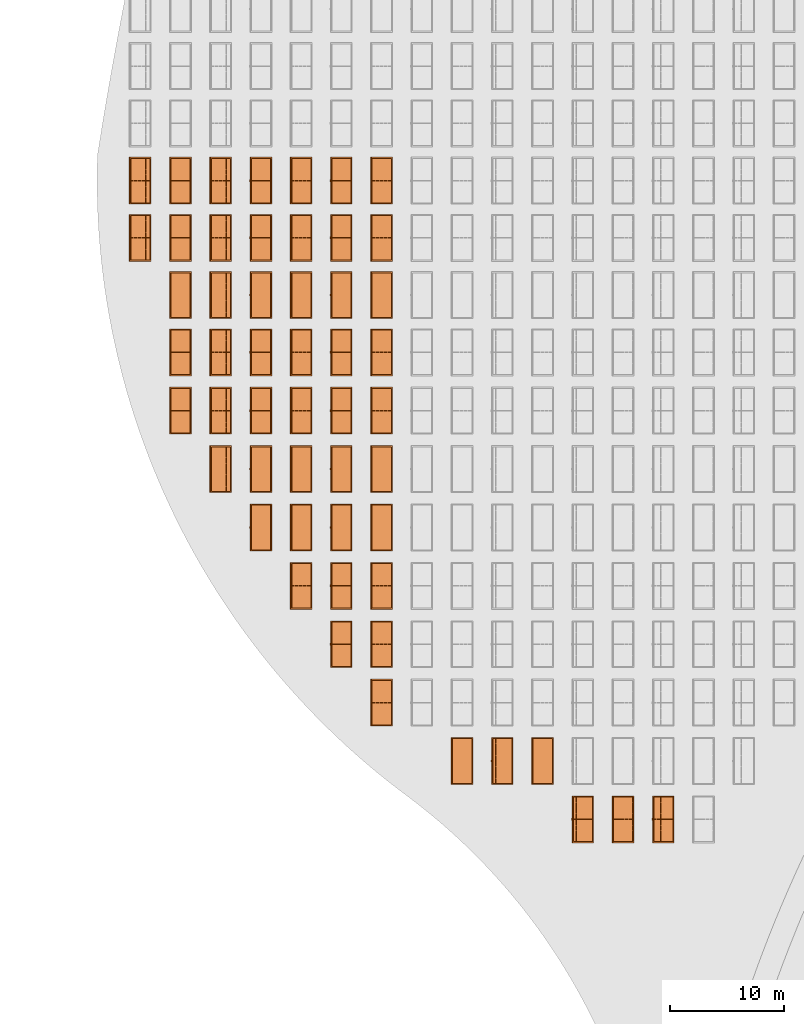
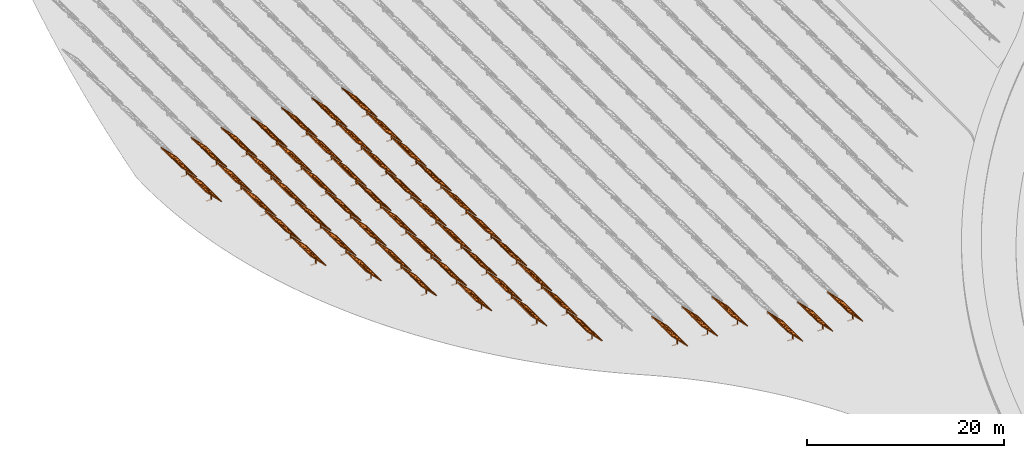
# One storey, part 15 of 39: 53 proxies.
"""IFC2X3 building model written with IfcOpenShell, lengths in millimetres."""

from ifc_helpers import new_model, entity, si_unit, converted_unit, derived_unit, direction, frame, frame_2d, origin, origin_2d_with_axis, place, context, subcontext, project, spatial, polyline, rectangle, outline, extrude, source, transform, mapped, material, material_list, element, save


model = new_model("IFC2X3")

# Units and contexts
model_context = context("Model", 3, precision=1e-06, world=origin(), true_north=direction((2.0, 6.12303176911189e-17, 1.0)))
context_of_model = context(None, 3, precision=1e-06, world=origin(), true_north=direction((2.0, 6.12303176911189e-17, 1.0)))
body_context = subcontext(model_context, "Body", "Model", "MODEL_VIEW")
ifc_project = project(units=[si_unit("LENGTHUNIT", "METRE", prefix="MILLI"), si_unit("AREAUNIT", "SQUARE_METRE", prefix="MILLI"), si_unit("VOLUMEUNIT", "CUBIC_METRE", prefix="MILLI"), converted_unit("PLANEANGLEUNIT", "DEGREE", entity("IfcRatioMeasure", 0.0174532925199433), si_unit("PLANEANGLEUNIT", "RADIAN"), dimensions=[0, 0, 0, 0, 0, 0, 0]), si_unit("MASSUNIT", "GRAM", prefix="KILO"), si_unit("TIMEUNIT", "SECOND"), si_unit("THERMODYNAMICTEMPERATUREUNIT", "KELVIN"), derived_unit("THERMALTRANSMITTANCEUNIT", [(si_unit("MASSUNIT", "GRAM", prefix="KILO"), 1), (si_unit("THERMODYNAMICTEMPERATUREUNIT", "KELVIN"), -1), (si_unit("TIMEUNIT", "SECOND"), -3)]), derived_unit("VOLUMETRICFLOWRATEUNIT", [(si_unit("LENGTHUNIT", "METRE"), 3), (si_unit("TIMEUNIT", "SECOND"), -1)])], contexts=[model_context, context_of_model])

# Site, building, storey
site_placement = place(None, origin())
site = spatial("IfcSite", under=ifc_project, at=site_placement, CompositionType="ELEMENT")
building_placement = place(site_placement, origin())
building = spatial("IfcBuilding", under=site, at=building_placement, CompositionType="ELEMENT")
storey_placement = place(building_placement, frame((0.0, 0.0, 4000.0)))
storey = spatial("IfcBuildingStorey", under=building, at=storey_placement, Name="Level 2", CompositionType="ELEMENT", Elevation=4000.0)

# Proxies
ifc_material_1 = material(Name="Stand-Steel")
ifc_material_2 = material(Name="Aluminium")
ifc_material_3 = material(Name="Glass")
ifc_material_list_1 = material_list([ifc_material_1, ifc_material_2, ifc_material_3])
shared_shape = source(origin(), body_context, "Body", "SweptSolid", [
    extrude(outline(polyline([(-629.526235435404, -220.0), (329.763117717702, -220.0), (329.763117717703, 410.0), (299.763117717703, 410.0), (299.763117717702, -190.0), (-629.526235435404, -190.0), (-629.526235435404, -220.0)])), frame((-190.00003127179, -100.0, 299.763117717707), z_axis=(0.0, 1.0, 0.0), x_axis=(0.0, 0.0, -1.0)), (0.0, 0.0, 1.0), 200.0),
    extrude(rectangle(XDim=20.0000000000001, YDim=200.0, at=frame_2d((0.0, -7.105427357601e-14), x_axis=(0.0, 1.0))), frame((-7.07109908365613, 0.0, 922.21828534124), z_axis=(-0.70710678118654, 0.0, 0.707106781186555), x_axis=(0.0, 1.0, 0.0)), (0.0, 0.0, 1.0), 2600.0),
    extrude(rectangle(XDim=24.9999999999997, YDim=24.9999999999999, at=frame_2d((2.87769807982841e-13, -9.50350909079134e-14), x_axis=(1.0, 0.0))), frame((-1449.56292018118, -1950.0, 2449.57494522722), z_axis=(0.0, 1.0, 0.0), x_axis=(-0.707106781186548, 0.0, -0.707106781186548)), (0.0, 0.0, 1.0), 3900.0),
    extrude(rectangle(XDim=24.9999999999999, YDim=25.0000000000001, at=origin_2d_with_axis()), frame((-1096.0095295879, -1950.0, 2096.02155463395), z_axis=(0.0, 1.0, 0.0), x_axis=(-0.707106781186542, 0.0, -0.707106781186553)), (0.0, 0.0, 1.0), 3900.0),
    extrude(rectangle(XDim=24.9999999999999, YDim=25.0000000000001, at=origin_2d_with_axis()), frame((-742.456138994631, -1950.0, 1742.46816404067), z_axis=(0.0, 1.0, 0.0), x_axis=(-0.707106781186542, 0.0, -0.707106781186553)), (0.0, 0.0, 1.0), 3900.0),
    extrude(rectangle(XDim=25.0, YDim=24.9999999999997, at=frame_2d((-7.19424519957101e-14, 1.19904086659517e-13), x_axis=(1.0, 0.0))), frame((-388.902748401358, -1950.0, 1388.9147734474), z_axis=(0.0, 1.0, 0.0), x_axis=(-0.707106781186545, 0.0, -0.70710678118655)), (0.0, 0.0, 1.0), 3900.0),
    extrude(rectangle(XDim=25.0000000000002, YDim=25.0, at=frame_2d((1.35891298214119e-13, 6.21724893790088e-15), x_axis=(0.0, 1.0))), frame((-35.3553703311048, 1500.0, 1035.35537033109), z_axis=(-0.707106781186544, 0.0, 0.707106781186551), x_axis=(0.0, 1.0, 0.0)), (0.0, 0.0, 1.0), 2440.0),
    extrude(rectangle(XDim=25.0000000000002, YDim=25.0, at=frame_2d((0.0, 1.77635683940025e-15), x_axis=(0.0, 1.0))), frame((-35.3553703311059, 1000.0, 1035.35537033109), z_axis=(-0.707106781186546, 0.0, 0.707106781186549), x_axis=(0.0, 1.0, 0.0)), (0.0, 0.0, 1.0), 2440.0),
    extrude(rectangle(XDim=25.0000000000002, YDim=25.0, at=frame_2d((0.0, 8.43769498715119e-14), x_axis=(0.0, 1.0))), frame((-26.5165355662756, 0.0, 1044.19420509593), z_axis=(-0.707106781186546, 0.0, 0.707106781186549), x_axis=(0.0, -1.0, 0.0)), (0.0, 0.0, 1.0), 2440.0),
    extrude(rectangle(XDim=25.0000000000002, YDim=25.0, at=frame_2d((0.0, 8.88178419700125e-16), x_axis=(0.0, 1.0))), frame((-35.3553703311065, 500.0, 1035.35537033109), z_axis=(-0.707106781186546, 0.0, 0.707106781186549), x_axis=(0.0, 1.0, 0.0)), (0.0, 0.0, 1.0), 2440.0),
    extrude(rectangle(XDim=25.0000000000002, YDim=25.0, at=frame_2d((0.0, 8.88178419700125e-16), x_axis=(0.0, 1.0))), frame((-35.3553703311086, -500.0, 1035.35537033109), z_axis=(-0.707106781186546, 0.0, 0.707106781186549), x_axis=(0.0, 1.0, 0.0)), (0.0, 0.0, 1.0), 2440.0),
    extrude(rectangle(XDim=25.0000000000002, YDim=25.0, at=frame_2d((0.0, 8.88178419700125e-16), x_axis=(0.0, 1.0))), frame((-35.3553703311095, -1000.0, 1035.35537033109), z_axis=(-0.707106781186546, 0.0, 0.707106781186549), x_axis=(0.0, 1.0, 0.0)), (0.0, 0.0, 1.0), 2440.0),
    extrude(rectangle(XDim=25.0000000000002, YDim=25.0, at=frame_2d((1.35891298214119e-13, 1.77635683940025e-15), x_axis=(0.0, 1.0))), frame((-35.3553703311107, -1500.0, 1035.35537033109), z_axis=(-0.707106781186546, 0.0, 0.707106781186549), x_axis=(0.0, 1.0, 0.0)), (0.0, 0.0, 1.0), 2440.0),
    extrude(rectangle(XDim=2400.0, YDim=11.9999999999994, at=frame_2d((-1.13686837721616e-13, 2.02948768901479e-13), x_axis=(1.0, 0.0))), frame((-883.883507754966, -1950.0, 1883.88350775495), z_axis=(0.0, 1.0, 0.0), x_axis=(0.707106781186546, 0.0, -0.707106781186549)), (0.0, 0.0, 1.0), 3900.0),
    extrude(outline(polyline([(-2050.0, -1300.0), (2050.0, -1300.0), (2050.0, 1300.0), (-2050.0, 1300.0), (-2050.0, -1300.0)]), holes=[polyline([(1950.0, -1200.0), (-1950.0, -1200.0), (-1950.0, 1200.0), (1950.0, 1200.0), (1950.0, -1200.0)])]), frame((-919.238846814293, 0.0, 1848.52816869563), z_axis=(0.707106781186554, 0.0, 0.707106781186541), x_axis=(0.0, 1.0, 0.0)), (0.0, 0.0, 1.0), 99.9999999999898),
])
proxy_1_placement = place(storey_placement, frame((-209095.328311831, 485144.680552409, 30.0)))
element("IfcBuildingElementProxy", 1, at=proxy_1_placement, inside=storey, material=ifc_material_list_1, Name="Solar Panel_4000X2500:Solar Panel_4000X2500", ObjectType="Solar Panel_4000X2500", CompositionType="ELEMENT", context=body_context, shape_type="MappedRepresentation", body=[
    mapped(shared_shape, transform((0.0, 0.0, 0.0), scale=1.0)),
])
ifc_material_list_2 = material_list([ifc_material_1, ifc_material_2, ifc_material_3])
proxy_2_placement = place(storey_placement, frame((-209095.328311831, 490144.680552409, 30.0)))
element("IfcBuildingElementProxy", 2, at=proxy_2_placement, inside=storey, material=ifc_material_list_2, Name="Solar Panel_4000X2500:Solar Panel_4000X2500", ObjectType="Solar Panel_4000X2500", CompositionType="ELEMENT", context=body_context, shape_type="MappedRepresentation", body=[
    mapped(shared_shape, transform((0.0, 0.0, 0.0), scale=1.0)),
])
ifc_material_list_3 = material_list([ifc_material_1, ifc_material_2, ifc_material_3])
proxy_3_placement = place(storey_placement, frame((-209095.328311831, 495144.680552409, 30.0)))
element("IfcBuildingElementProxy", 3, at=proxy_3_placement, inside=storey, material=ifc_material_list_3, Name="Solar Panel_4000X2500:Solar Panel_4000X2500", ObjectType="Solar Panel_4000X2500", CompositionType="ELEMENT", context=body_context, shape_type="MappedRepresentation", body=[
    mapped(shared_shape, transform((0.0, 0.0, 0.0), scale=1.0)),
])
ifc_material_list_4 = material_list([ifc_material_1, ifc_material_2, ifc_material_3])
proxy_4_placement = place(storey_placement, frame((-209095.328311831, 480144.680552409, 30.0)))
element("IfcBuildingElementProxy", 4, at=proxy_4_placement, inside=storey, material=ifc_material_list_4, Name="Solar Panel_4000X2500:Solar Panel_4000X2500", ObjectType="Solar Panel_4000X2500", CompositionType="ELEMENT", context=body_context, shape_type="MappedRepresentation", body=[
    mapped(shared_shape, transform((0.0, 0.0, 0.0), scale=1.0)),
])
ifc_material_list_5 = material_list([ifc_material_1, ifc_material_2, ifc_material_3])
proxy_5_placement = place(storey_placement, frame((-209095.328311831, 475044.680552409, 30.0)))
element("IfcBuildingElementProxy", 5, at=proxy_5_placement, inside=storey, material=ifc_material_list_5, Name="Solar Panel_4000X2500:Solar Panel_4000X2500", ObjectType="Solar Panel_4000X2500", CompositionType="ELEMENT", context=body_context, shape_type="MappedRepresentation", body=[
    mapped(shared_shape, transform((0.0, 0.0, 0.0), scale=1.0)),
])
ifc_material_list_6 = material_list([ifc_material_1, ifc_material_2, ifc_material_3])
proxy_6_placement = place(storey_placement, frame((-209095.328311831, 469944.680552409, 30.0)))
element("IfcBuildingElementProxy", 6, at=proxy_6_placement, inside=storey, material=ifc_material_list_6, Name="Solar Panel_4000X2500:Solar Panel_4000X2500", ObjectType="Solar Panel_4000X2500", CompositionType="ELEMENT", context=body_context, shape_type="MappedRepresentation", body=[
    mapped(shared_shape, transform((0.0, 0.0, 0.0), scale=1.0)),
])
ifc_material_list_7 = material_list([ifc_material_1, ifc_material_2, ifc_material_3])
proxy_7_placement = place(storey_placement, frame((-212610.328311831, 485144.680552409, 30.0)))
element("IfcBuildingElementProxy", 7, at=proxy_7_placement, inside=storey, material=ifc_material_list_7, Name="Solar Panel_4000X2500:Solar Panel_4000X2500", ObjectType="Solar Panel_4000X2500", CompositionType="ELEMENT", context=body_context, shape_type="MappedRepresentation", body=[
    mapped(shared_shape, transform((0.0, 0.0, 0.0), scale=1.0)),
])
ifc_material_list_8 = material_list([ifc_material_1, ifc_material_2, ifc_material_3])
proxy_8_placement = place(storey_placement, frame((-212610.328311831, 490144.680552409, 30.0)))
element("IfcBuildingElementProxy", 8, at=proxy_8_placement, inside=storey, material=ifc_material_list_8, Name="Solar Panel_4000X2500:Solar Panel_4000X2500", ObjectType="Solar Panel_4000X2500", CompositionType="ELEMENT", context=body_context, shape_type="MappedRepresentation", body=[
    mapped(shared_shape, transform((0.0, 0.0, 0.0), scale=1.0)),
])
ifc_material_list_9 = material_list([ifc_material_1, ifc_material_2, ifc_material_3])
proxy_9_placement = place(storey_placement, frame((-212610.328311831, 495144.680552409, 30.0)))
element("IfcBuildingElementProxy", 9, at=proxy_9_placement, inside=storey, material=ifc_material_list_9, Name="Solar Panel_4000X2500:Solar Panel_4000X2500", ObjectType="Solar Panel_4000X2500", CompositionType="ELEMENT", context=body_context, shape_type="MappedRepresentation", body=[
    mapped(shared_shape, transform((0.0, 0.0, 0.0), scale=1.0)),
])
ifc_material_list_10 = material_list([ifc_material_1, ifc_material_2, ifc_material_3])
proxy_10_placement = place(storey_placement, frame((-212610.328311831, 480144.680552409, 30.0)))
element("IfcBuildingElementProxy", 10, at=proxy_10_placement, inside=storey, material=ifc_material_list_10, Name="Solar Panel_4000X2500:Solar Panel_4000X2500", ObjectType="Solar Panel_4000X2500", CompositionType="ELEMENT", context=body_context, shape_type="MappedRepresentation", body=[
    mapped(shared_shape, transform((0.0, 0.0, 0.0), scale=1.0)),
])
ifc_material_list_11 = material_list([ifc_material_1, ifc_material_2, ifc_material_3])
proxy_11_placement = place(storey_placement, frame((-212610.328311831, 475044.680552409, 30.0)))
element("IfcBuildingElementProxy", 11, at=proxy_11_placement, inside=storey, material=ifc_material_list_11, Name="Solar Panel_4000X2500:Solar Panel_4000X2500", ObjectType="Solar Panel_4000X2500", CompositionType="ELEMENT", context=body_context, shape_type="MappedRepresentation", body=[
    mapped(shared_shape, transform((0.0, 0.0, 0.0), scale=1.0)),
])
ifc_material_list_12 = material_list([ifc_material_1, ifc_material_2, ifc_material_3])
proxy_12_placement = place(storey_placement, frame((-212610.328311831, 469944.680552409, 30.0)))
element("IfcBuildingElementProxy", 12, at=proxy_12_placement, inside=storey, material=ifc_material_list_12, Name="Solar Panel_4000X2500:Solar Panel_4000X2500", ObjectType="Solar Panel_4000X2500", CompositionType="ELEMENT", context=body_context, shape_type="MappedRepresentation", body=[
    mapped(shared_shape, transform((0.0, 0.0, 0.0), scale=1.0)),
])
ifc_material_list_13 = material_list([ifc_material_1, ifc_material_2, ifc_material_3])
proxy_13_placement = place(storey_placement, frame((-216125.328311831, 485144.680552409, 30.0)))
element("IfcBuildingElementProxy", 13, at=proxy_13_placement, inside=storey, material=ifc_material_list_13, Name="Solar Panel_4000X2500:Solar Panel_4000X2500", ObjectType="Solar Panel_4000X2500", CompositionType="ELEMENT", context=body_context, shape_type="MappedRepresentation", body=[
    mapped(shared_shape, transform((0.0, 0.0, 0.0), scale=1.0)),
])
ifc_material_list_14 = material_list([ifc_material_1, ifc_material_2, ifc_material_3])
proxy_14_placement = place(storey_placement, frame((-216125.328311831, 490144.680552409, 30.0)))
element("IfcBuildingElementProxy", 14, at=proxy_14_placement, inside=storey, material=ifc_material_list_14, Name="Solar Panel_4000X2500:Solar Panel_4000X2500", ObjectType="Solar Panel_4000X2500", CompositionType="ELEMENT", context=body_context, shape_type="MappedRepresentation", body=[
    mapped(shared_shape, transform((0.0, 0.0, 0.0), scale=1.0)),
])
ifc_material_list_15 = material_list([ifc_material_1, ifc_material_2, ifc_material_3])
proxy_15_placement = place(storey_placement, frame((-216125.328311831, 495144.680552409, 30.0)))
element("IfcBuildingElementProxy", 15, at=proxy_15_placement, inside=storey, material=ifc_material_list_15, Name="Solar Panel_4000X2500:Solar Panel_4000X2500", ObjectType="Solar Panel_4000X2500", CompositionType="ELEMENT", context=body_context, shape_type="MappedRepresentation", body=[
    mapped(shared_shape, transform((0.0, 0.0, 0.0), scale=1.0)),
])
ifc_material_list_16 = material_list([ifc_material_1, ifc_material_2, ifc_material_3])
proxy_16_placement = place(storey_placement, frame((-216125.328311831, 480144.680552409, 30.0)))
element("IfcBuildingElementProxy", 16, at=proxy_16_placement, inside=storey, material=ifc_material_list_16, Name="Solar Panel_4000X2500:Solar Panel_4000X2500", ObjectType="Solar Panel_4000X2500", CompositionType="ELEMENT", context=body_context, shape_type="MappedRepresentation", body=[
    mapped(shared_shape, transform((0.0, 0.0, 0.0), scale=1.0)),
])
ifc_material_list_17 = material_list([ifc_material_1, ifc_material_2, ifc_material_3])
proxy_17_placement = place(storey_placement, frame((-216125.328311831, 475044.680552409, 30.0)))
element("IfcBuildingElementProxy", 17, at=proxy_17_placement, inside=storey, material=ifc_material_list_17, Name="Solar Panel_4000X2500:Solar Panel_4000X2500", ObjectType="Solar Panel_4000X2500", CompositionType="ELEMENT", context=body_context, shape_type="MappedRepresentation", body=[
    mapped(shared_shape, transform((0.0, 0.0, 0.0), scale=1.0)),
])
ifc_material_list_18 = material_list([ifc_material_1, ifc_material_2, ifc_material_3])
proxy_18_placement = place(storey_placement, frame((-216125.328311831, 469944.680552409, 30.0)))
element("IfcBuildingElementProxy", 18, at=proxy_18_placement, inside=storey, material=ifc_material_list_18, Name="Solar Panel_4000X2500:Solar Panel_4000X2500", ObjectType="Solar Panel_4000X2500", CompositionType="ELEMENT", context=body_context, shape_type="MappedRepresentation", body=[
    mapped(shared_shape, transform((0.0, 0.0, 0.0), scale=1.0)),
])
ifc_material_list_19 = material_list([ifc_material_1, ifc_material_2, ifc_material_3])
proxy_19_placement = place(storey_placement, frame((-219640.328311831, 485144.680552409, 30.0)))
element("IfcBuildingElementProxy", 19, at=proxy_19_placement, inside=storey, material=ifc_material_list_19, Name="Solar Panel_4000X2500:Solar Panel_4000X2500", ObjectType="Solar Panel_4000X2500", CompositionType="ELEMENT", context=body_context, shape_type="MappedRepresentation", body=[
    mapped(shared_shape, transform((0.0, 0.0, 0.0), scale=1.0)),
])
ifc_material_list_20 = material_list([ifc_material_1, ifc_material_2, ifc_material_3])
proxy_20_placement = place(storey_placement, frame((-219640.328311831, 490144.680552409, 30.0)))
element("IfcBuildingElementProxy", 20, at=proxy_20_placement, inside=storey, material=ifc_material_list_20, Name="Solar Panel_4000X2500:Solar Panel_4000X2500", ObjectType="Solar Panel_4000X2500", CompositionType="ELEMENT", context=body_context, shape_type="MappedRepresentation", body=[
    mapped(shared_shape, transform((0.0, 0.0, 0.0), scale=1.0)),
])
ifc_material_list_21 = material_list([ifc_material_1, ifc_material_2, ifc_material_3])
proxy_21_placement = place(storey_placement, frame((-219640.328311831, 495144.680552409, 30.0)))
element("IfcBuildingElementProxy", 21, at=proxy_21_placement, inside=storey, material=ifc_material_list_21, Name="Solar Panel_4000X2500:Solar Panel_4000X2500", ObjectType="Solar Panel_4000X2500", CompositionType="ELEMENT", context=body_context, shape_type="MappedRepresentation", body=[
    mapped(shared_shape, transform((0.0, 0.0, 0.0), scale=1.0)),
])
ifc_material_list_22 = material_list([ifc_material_1, ifc_material_2, ifc_material_3])
proxy_22_placement = place(storey_placement, frame((-219640.328311831, 480144.680552409, 30.0)))
element("IfcBuildingElementProxy", 22, at=proxy_22_placement, inside=storey, material=ifc_material_list_22, Name="Solar Panel_4000X2500:Solar Panel_4000X2500", ObjectType="Solar Panel_4000X2500", CompositionType="ELEMENT", context=body_context, shape_type="MappedRepresentation", body=[
    mapped(shared_shape, transform((0.0, 0.0, 0.0), scale=1.0)),
])
ifc_material_list_23 = material_list([ifc_material_1, ifc_material_2, ifc_material_3])
proxy_23_placement = place(storey_placement, frame((-219640.328311831, 475044.680552409, 30.0)))
element("IfcBuildingElementProxy", 23, at=proxy_23_placement, inside=storey, material=ifc_material_list_23, Name="Solar Panel_4000X2500:Solar Panel_4000X2500", ObjectType="Solar Panel_4000X2500", CompositionType="ELEMENT", context=body_context, shape_type="MappedRepresentation", body=[
    mapped(shared_shape, transform((0.0, 0.0, 0.0), scale=1.0)),
])
ifc_material_list_24 = material_list([ifc_material_1, ifc_material_2, ifc_material_3])
proxy_24_placement = place(storey_placement, frame((-219640.328311831, 469944.680552409, 30.0)))
element("IfcBuildingElementProxy", 24, at=proxy_24_placement, inside=storey, material=ifc_material_list_24, Name="Solar Panel_4000X2500:Solar Panel_4000X2500", ObjectType="Solar Panel_4000X2500", CompositionType="ELEMENT", context=body_context, shape_type="MappedRepresentation", body=[
    mapped(shared_shape, transform((0.0, 0.0, 0.0), scale=1.0)),
])
ifc_material_list_25 = material_list([ifc_material_1, ifc_material_2, ifc_material_3])
proxy_25_placement = place(storey_placement, frame((-223155.328311831, 485144.680552409, 30.0)))
element("IfcBuildingElementProxy", 25, at=proxy_25_placement, inside=storey, material=ifc_material_list_25, Name="Solar Panel_4000X2500:Solar Panel_4000X2500", ObjectType="Solar Panel_4000X2500", CompositionType="ELEMENT", context=body_context, shape_type="MappedRepresentation", body=[
    mapped(shared_shape, transform((0.0, 0.0, 0.0), scale=1.0)),
])
ifc_material_list_26 = material_list([ifc_material_1, ifc_material_2, ifc_material_3])
proxy_26_placement = place(storey_placement, frame((-223155.328311831, 490144.680552409, 30.0)))
element("IfcBuildingElementProxy", 26, at=proxy_26_placement, inside=storey, material=ifc_material_list_26, Name="Solar Panel_4000X2500:Solar Panel_4000X2500", ObjectType="Solar Panel_4000X2500", CompositionType="ELEMENT", context=body_context, shape_type="MappedRepresentation", body=[
    mapped(shared_shape, transform((0.0, 0.0, 0.0), scale=1.0)),
])
ifc_material_list_27 = material_list([ifc_material_1, ifc_material_2, ifc_material_3])
proxy_27_placement = place(storey_placement, frame((-223155.328311831, 495144.680552409, 30.0)))
element("IfcBuildingElementProxy", 27, at=proxy_27_placement, inside=storey, material=ifc_material_list_27, Name="Solar Panel_4000X2500:Solar Panel_4000X2500", ObjectType="Solar Panel_4000X2500", CompositionType="ELEMENT", context=body_context, shape_type="MappedRepresentation", body=[
    mapped(shared_shape, transform((0.0, 0.0, 0.0), scale=1.0)),
])
ifc_material_list_28 = material_list([ifc_material_1, ifc_material_2, ifc_material_3])
proxy_28_placement = place(storey_placement, frame((-223155.328311831, 480144.680552409, 30.0)))
element("IfcBuildingElementProxy", 28, at=proxy_28_placement, inside=storey, material=ifc_material_list_28, Name="Solar Panel_4000X2500:Solar Panel_4000X2500", ObjectType="Solar Panel_4000X2500", CompositionType="ELEMENT", context=body_context, shape_type="MappedRepresentation", body=[
    mapped(shared_shape, transform((0.0, 0.0, 0.0), scale=1.0)),
])
ifc_material_list_29 = material_list([ifc_material_1, ifc_material_2, ifc_material_3])
proxy_29_placement = place(storey_placement, frame((-223155.328311831, 475044.680552409, 30.0)))
element("IfcBuildingElementProxy", 29, at=proxy_29_placement, inside=storey, material=ifc_material_list_29, Name="Solar Panel_4000X2500:Solar Panel_4000X2500", ObjectType="Solar Panel_4000X2500", CompositionType="ELEMENT", context=body_context, shape_type="MappedRepresentation", body=[
    mapped(shared_shape, transform((0.0, 0.0, 0.0), scale=1.0)),
])
ifc_material_list_30 = material_list([ifc_material_1, ifc_material_2, ifc_material_3])
proxy_30_placement = place(storey_placement, frame((-223155.328311831, 469944.680552409, 30.0)))
element("IfcBuildingElementProxy", 30, at=proxy_30_placement, inside=storey, material=ifc_material_list_30, Name="Solar Panel_4000X2500:Solar Panel_4000X2500", ObjectType="Solar Panel_4000X2500", CompositionType="ELEMENT", context=body_context, shape_type="MappedRepresentation", body=[
    mapped(shared_shape, transform((0.0, 0.0, 0.0), scale=1.0)),
])
ifc_material_list_31 = material_list([ifc_material_1, ifc_material_2, ifc_material_3])
proxy_31_placement = place(storey_placement, frame((-226670.328311831, 485144.680552409, 30.0)))
element("IfcBuildingElementProxy", 31, at=proxy_31_placement, inside=storey, material=ifc_material_list_31, Name="Solar Panel_4000X2500:Solar Panel_4000X2500", ObjectType="Solar Panel_4000X2500", CompositionType="ELEMENT", context=body_context, shape_type="MappedRepresentation", body=[
    mapped(shared_shape, transform((0.0, 0.0, 0.0), scale=1.0)),
])
ifc_material_list_32 = material_list([ifc_material_1, ifc_material_2, ifc_material_3])
proxy_32_placement = place(storey_placement, frame((-226670.328311831, 490144.680552409, 30.0)))
element("IfcBuildingElementProxy", 32, at=proxy_32_placement, inside=storey, material=ifc_material_list_32, Name="Solar Panel_4000X2500:Solar Panel_4000X2500", ObjectType="Solar Panel_4000X2500", CompositionType="ELEMENT", context=body_context, shape_type="MappedRepresentation", body=[
    mapped(shared_shape, transform((0.0, 0.0, 0.0), scale=1.0)),
])
ifc_material_list_33 = material_list([ifc_material_1, ifc_material_2, ifc_material_3])
proxy_33_placement = place(storey_placement, frame((-226670.328311831, 495144.680552409, 30.0)))
element("IfcBuildingElementProxy", 33, at=proxy_33_placement, inside=storey, material=ifc_material_list_33, Name="Solar Panel_4000X2500:Solar Panel_4000X2500", ObjectType="Solar Panel_4000X2500", CompositionType="ELEMENT", context=body_context, shape_type="MappedRepresentation", body=[
    mapped(shared_shape, transform((0.0, 0.0, 0.0), scale=1.0)),
])
ifc_material_list_34 = material_list([ifc_material_1, ifc_material_2, ifc_material_3])
proxy_34_placement = place(storey_placement, frame((-226670.328311831, 480144.680552409, 30.0)))
element("IfcBuildingElementProxy", 34, at=proxy_34_placement, inside=storey, material=ifc_material_list_34, Name="Solar Panel_4000X2500:Solar Panel_4000X2500", ObjectType="Solar Panel_4000X2500", CompositionType="ELEMENT", context=body_context, shape_type="MappedRepresentation", body=[
    mapped(shared_shape, transform((0.0, 0.0, 0.0), scale=1.0)),
])
ifc_material_list_35 = material_list([ifc_material_1, ifc_material_2, ifc_material_3])
proxy_35_placement = place(storey_placement, frame((-226670.328311831, 475044.680552409, 30.0)))
element("IfcBuildingElementProxy", 35, at=proxy_35_placement, inside=storey, material=ifc_material_list_35, Name="Solar Panel_4000X2500:Solar Panel_4000X2500", ObjectType="Solar Panel_4000X2500", CompositionType="ELEMENT", context=body_context, shape_type="MappedRepresentation", body=[
    mapped(shared_shape, transform((0.0, 0.0, 0.0), scale=1.0)),
])
ifc_material_list_36 = material_list([ifc_material_1, ifc_material_2, ifc_material_3])
proxy_36_placement = place(storey_placement, frame((-230185.328311831, 490144.680552409, 30.0)))
element("IfcBuildingElementProxy", 36, at=proxy_36_placement, inside=storey, material=ifc_material_list_36, Name="Solar Panel_4000X2500:Solar Panel_4000X2500", ObjectType="Solar Panel_4000X2500", CompositionType="ELEMENT", context=body_context, shape_type="MappedRepresentation", body=[
    mapped(shared_shape, transform((0.0, 0.0, 0.0), scale=1.0)),
])
ifc_material_list_37 = material_list([ifc_material_1, ifc_material_2, ifc_material_3])
proxy_37_placement = place(storey_placement, frame((-230185.328311831, 495144.680552409, 30.0)))
element("IfcBuildingElementProxy", 37, at=proxy_37_placement, inside=storey, material=ifc_material_list_37, Name="Solar Panel_4000X2500:Solar Panel_4000X2500", ObjectType="Solar Panel_4000X2500", CompositionType="ELEMENT", context=body_context, shape_type="MappedRepresentation", body=[
    mapped(shared_shape, transform((0.0, 0.0, 0.0), scale=1.0)),
])
ifc_material_list_38 = material_list([ifc_material_1, ifc_material_2, ifc_material_3])
proxy_38_placement = place(storey_placement, frame((-209095.328311831, 464844.680552409, 30.0)))
element("IfcBuildingElementProxy", 38, at=proxy_38_placement, inside=storey, material=ifc_material_list_38, Name="Solar Panel_4000X2500:Solar Panel_4000X2500", ObjectType="Solar Panel_4000X2500", CompositionType="ELEMENT", context=body_context, shape_type="MappedRepresentation", body=[
    mapped(shared_shape, transform((0.0, 0.0, 0.0), scale=1.0)),
])
ifc_material_list_39 = material_list([ifc_material_1, ifc_material_2, ifc_material_3])
proxy_39_placement = place(storey_placement, frame((-212610.328311831, 464844.680552409, 30.0)))
element("IfcBuildingElementProxy", 39, at=proxy_39_placement, inside=storey, material=ifc_material_list_39, Name="Solar Panel_4000X2500:Solar Panel_4000X2500", ObjectType="Solar Panel_4000X2500", CompositionType="ELEMENT", context=body_context, shape_type="MappedRepresentation", body=[
    mapped(shared_shape, transform((0.0, 0.0, 0.0), scale=1.0)),
])
ifc_material_list_40 = material_list([ifc_material_1, ifc_material_2, ifc_material_3])
proxy_40_placement = place(storey_placement, frame((-216125.328311831, 464844.680552409, 30.0)))
element("IfcBuildingElementProxy", 40, at=proxy_40_placement, inside=storey, material=ifc_material_list_40, Name="Solar Panel_4000X2500:Solar Panel_4000X2500", ObjectType="Solar Panel_4000X2500", CompositionType="ELEMENT", context=body_context, shape_type="MappedRepresentation", body=[
    mapped(shared_shape, transform((0.0, 0.0, 0.0), scale=1.0)),
])
ifc_material_list_41 = material_list([ifc_material_1, ifc_material_2, ifc_material_3])
proxy_41_placement = place(storey_placement, frame((-219640.328311831, 464844.680552409, 30.0)))
element("IfcBuildingElementProxy", 41, at=proxy_41_placement, inside=storey, material=ifc_material_list_41, Name="Solar Panel_4000X2500:Solar Panel_4000X2500", ObjectType="Solar Panel_4000X2500", CompositionType="ELEMENT", context=body_context, shape_type="MappedRepresentation", body=[
    mapped(shared_shape, transform((0.0, 0.0, 0.0), scale=1.0)),
])
ifc_material_list_42 = material_list([ifc_material_1, ifc_material_2, ifc_material_3])
proxy_42_placement = place(storey_placement, frame((-209095.328311831, 459744.680552409, 30.0)))
element("IfcBuildingElementProxy", 42, at=proxy_42_placement, inside=storey, material=ifc_material_list_42, Name="Solar Panel_4000X2500:Solar Panel_4000X2500", ObjectType="Solar Panel_4000X2500", CompositionType="ELEMENT", context=body_context, shape_type="MappedRepresentation", body=[
    mapped(shared_shape, transform((0.0, 0.0, 0.0), scale=1.0)),
])
ifc_material_list_43 = material_list([ifc_material_1, ifc_material_2, ifc_material_3])
proxy_43_placement = place(storey_placement, frame((-212610.328311831, 459744.680552409, 30.0)))
element("IfcBuildingElementProxy", 43, at=proxy_43_placement, inside=storey, material=ifc_material_list_43, Name="Solar Panel_4000X2500:Solar Panel_4000X2500", ObjectType="Solar Panel_4000X2500", CompositionType="ELEMENT", context=body_context, shape_type="MappedRepresentation", body=[
    mapped(shared_shape, transform((0.0, 0.0, 0.0), scale=1.0)),
])
ifc_material_list_44 = material_list([ifc_material_1, ifc_material_2, ifc_material_3])
proxy_44_placement = place(storey_placement, frame((-216125.328311831, 459744.680552409, 30.0)))
element("IfcBuildingElementProxy", 44, at=proxy_44_placement, inside=storey, material=ifc_material_list_44, Name="Solar Panel_4000X2500:Solar Panel_4000X2500", ObjectType="Solar Panel_4000X2500", CompositionType="ELEMENT", context=body_context, shape_type="MappedRepresentation", body=[
    mapped(shared_shape, transform((0.0, 0.0, 0.0), scale=1.0)),
])
ifc_material_list_45 = material_list([ifc_material_1, ifc_material_2, ifc_material_3])
proxy_45_placement = place(storey_placement, frame((-209095.328311831, 454644.680552409, 30.0)))
element("IfcBuildingElementProxy", 45, at=proxy_45_placement, inside=storey, material=ifc_material_list_45, Name="Solar Panel_4000X2500:Solar Panel_4000X2500", ObjectType="Solar Panel_4000X2500", CompositionType="ELEMENT", context=body_context, shape_type="MappedRepresentation", body=[
    mapped(shared_shape, transform((0.0, 0.0, 0.0), scale=1.0)),
])
ifc_material_list_46 = material_list([ifc_material_1, ifc_material_2, ifc_material_3])
proxy_46_placement = place(storey_placement, frame((-209095.328311831, 449544.680552409, 30.0)))
element("IfcBuildingElementProxy", 46, at=proxy_46_placement, inside=storey, material=ifc_material_list_46, Name="Solar Panel_4000X2500:Solar Panel_4000X2500", ObjectType="Solar Panel_4000X2500", CompositionType="ELEMENT", context=body_context, shape_type="MappedRepresentation", body=[
    mapped(shared_shape, transform((0.0, 0.0, 0.0), scale=1.0)),
])
ifc_material_list_47 = material_list([ifc_material_1, ifc_material_2, ifc_material_3])
proxy_47_placement = place(storey_placement, frame((-195035.32831183, 444444.680552409, 30.0)))
element("IfcBuildingElementProxy", 47, at=proxy_47_placement, inside=storey, material=ifc_material_list_47, Name="Solar Panel_4000X2500:Solar Panel_4000X2500", ObjectType="Solar Panel_4000X2500", CompositionType="ELEMENT", context=body_context, shape_type="MappedRepresentation", body=[
    mapped(shared_shape, transform((0.0, 0.0, 0.0), scale=1.0)),
])
ifc_material_list_48 = material_list([ifc_material_1, ifc_material_2, ifc_material_3])
proxy_48_placement = place(storey_placement, frame((-198550.32831183, 444444.680552409, 30.0)))
element("IfcBuildingElementProxy", 48, at=proxy_48_placement, inside=storey, material=ifc_material_list_48, Name="Solar Panel_4000X2500:Solar Panel_4000X2500", ObjectType="Solar Panel_4000X2500", CompositionType="ELEMENT", context=body_context, shape_type="MappedRepresentation", body=[
    mapped(shared_shape, transform((0.0, 0.0, 0.0), scale=1.0)),
])
ifc_material_list_49 = material_list([ifc_material_1, ifc_material_2, ifc_material_3])
proxy_49_placement = place(storey_placement, frame((-202065.32831183, 444444.680552409, 30.0)))
element("IfcBuildingElementProxy", 49, at=proxy_49_placement, inside=storey, material=ifc_material_list_49, Name="Solar Panel_4000X2500:Solar Panel_4000X2500", ObjectType="Solar Panel_4000X2500", CompositionType="ELEMENT", context=body_context, shape_type="MappedRepresentation", body=[
    mapped(shared_shape, transform((0.0, 0.0, 0.0), scale=1.0)),
])
ifc_material_list_50 = material_list([ifc_material_1, ifc_material_2, ifc_material_3])
proxy_50_placement = place(storey_placement, frame((-184490.32831183, 439344.680552409, 30.0)))
element("IfcBuildingElementProxy", 50, at=proxy_50_placement, inside=storey, material=ifc_material_list_50, Name="Solar Panel_4000X2500:Solar Panel_4000X2500", ObjectType="Solar Panel_4000X2500", CompositionType="ELEMENT", context=body_context, shape_type="MappedRepresentation", body=[
    mapped(shared_shape, transform((0.0, 0.0, 0.0), scale=1.0)),
])
ifc_material_list_51 = material_list([ifc_material_1, ifc_material_2, ifc_material_3])
proxy_51_placement = place(storey_placement, frame((-188005.32831183, 439344.680552409, 30.0)))
element("IfcBuildingElementProxy", 51, at=proxy_51_placement, inside=storey, material=ifc_material_list_51, Name="Solar Panel_4000X2500:Solar Panel_4000X2500", ObjectType="Solar Panel_4000X2500", CompositionType="ELEMENT", context=body_context, shape_type="MappedRepresentation", body=[
    mapped(shared_shape, transform((0.0, 0.0, 0.0), scale=1.0)),
])
ifc_material_list_52 = material_list([ifc_material_1, ifc_material_2, ifc_material_3])
proxy_52_placement = place(storey_placement, frame((-191520.32831183, 439344.680552409, 30.0)))
element("IfcBuildingElementProxy", 52, at=proxy_52_placement, inside=storey, material=ifc_material_list_52, Name="Solar Panel_4000X2500:Solar Panel_4000X2500", ObjectType="Solar Panel_4000X2500", CompositionType="ELEMENT", context=body_context, shape_type="MappedRepresentation", body=[
    mapped(shared_shape, transform((0.0, 0.0, 0.0), scale=1.0)),
])
ifc_material_list_53 = material_list([ifc_material_1, ifc_material_2, ifc_material_3])
proxy_53_placement = place(storey_placement, frame((-212610.328311831, 454644.680552409, 30.0)))
element("IfcBuildingElementProxy", 53, at=proxy_53_placement, inside=storey, material=ifc_material_list_53, Name="Solar Panel_4000X2500:Solar Panel_4000X2500", ObjectType="Solar Panel_4000X2500", CompositionType="ELEMENT", context=body_context, shape_type="MappedRepresentation", body=[
    mapped(shared_shape, transform((0.0, 0.0, 0.0), scale=1.0)),
])

save(model, "model.ifc")
